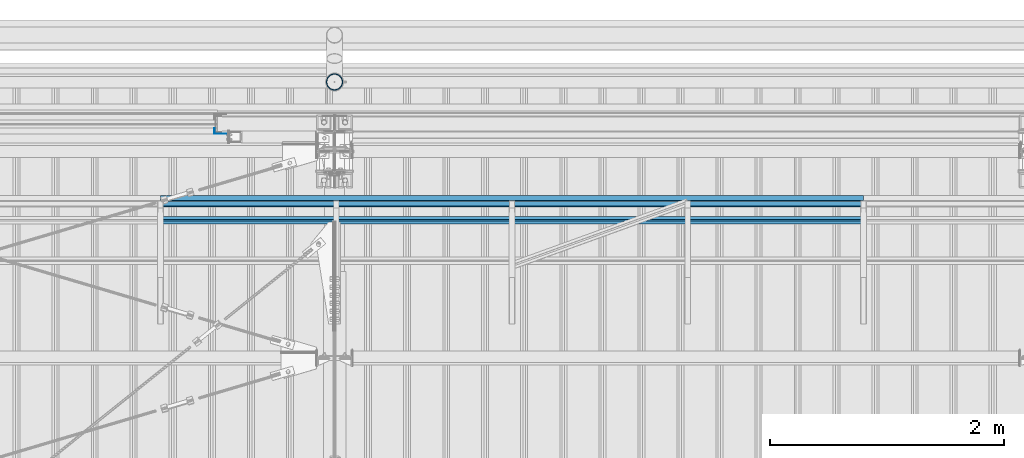
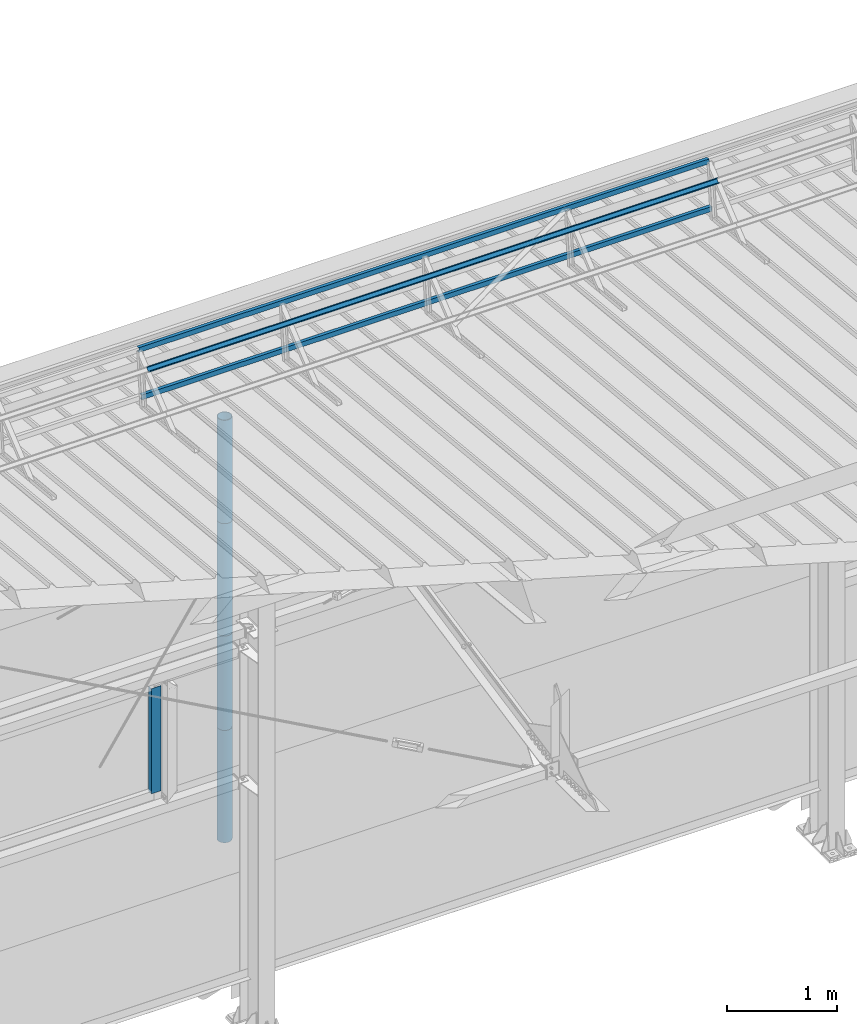
# One storey, part 55 of 709: 8 beams, 8 elements without a shape of their own.
"""IFC4 building model written with IfcOpenShell, lengths in millimetres."""

from ifc_helpers import new_model, si_unit, direction, frame, origin_with_axes, place, context, subcontext, project, spatial, line, indexed_curve, outline, extrude, material, element, aggregate, save


model = new_model("IFC4")

# Units and contexts
model_context = context("Model", 3, precision=0.2, world=origin_with_axes(), true_north=direction((0.0, 1.0)))
body_context = subcontext(model_context, "Body", "Model", "MODEL_VIEW")
ifc_project = project(units=[si_unit("LENGTHUNIT", "METRE", prefix="MILLI"), si_unit("AREAUNIT", "SQUARE_METRE"), si_unit("VOLUMEUNIT", "CUBIC_METRE"), si_unit("MASSUNIT", "GRAM", prefix="KILO"), si_unit("TIMEUNIT", "SECOND"), si_unit("PLANEANGLEUNIT", "RADIAN"), si_unit("SOLIDANGLEUNIT", "STERADIAN"), si_unit("THERMODYNAMICTEMPERATUREUNIT", "DEGREE_CELSIUS"), si_unit("LUMINOUSINTENSITYUNIT", "LUMEN")], contexts=[model_context])

# Site, building, storey
site_placement = place(None, origin_with_axes())
site = spatial("IfcSite", under=ifc_project, at=site_placement, CompositionType="ELEMENT")
building_placement = place(site_placement, origin_with_axes())
building = spatial("IfcBuilding", under=site, at=building_placement, Name="Undefined", CompositionType="ELEMENT")
storey_placement = place(building_placement, origin_with_axes())
storey = spatial("IfcBuildingStorey", under=building, at=storey_placement, Name="Undefined", CompositionType="ELEMENT", Elevation=0.0)

# Assembly, beam
assembly_1_placement = place(storey_placement, frame((14515.0, 21426.91216, 8140.47118), z_axis=(0.0, 0.9950371902, -0.099503719), x_axis=(-1.0, 0.0, 0.0)))
assembly_1 = element("IfcElementAssembly", 1, at=assembly_1_placement, inside=storey)
ifc_material = material(Name="Steel_Undefined", Category="STEEL")
beam_1_placement = place(assembly_1_placement, origin_with_axes())
beam_1 = element("IfcBeam", 2, at=beam_1_placement, material=ifc_material, ObjectType="606", context=body_context, shape_type="SolidModel", body=[
    extrude(outline(indexed_curve([(-20.0, -25.0), (20.0, -25.0), (20.0, -22.5), (-17.5, -22.5), (-17.5, 22.5), (20.0, 22.5), (20.0, 25.0), (-20.0, 25.0)], segments=[line(1, 2, 3, 4, 5, 6, 7, 8, 1)])), frame((0.0, 0.0, 0.0), z_axis=(-1.0, 0.0, 0.0), x_axis=(0.0, 0.0, 1.0)), (0.0, 0.0, -1.0), 6000.0),
])
aggregate(assembly_1, [beam_1])

assembly_2_placement = place(storey_placement, frame((14515.0, 21377.1603, 7642.95259), z_axis=(0.0, 0.9950371902, -0.099503719), x_axis=(-1.0, 0.0, 0.0)))
assembly_2 = element("IfcElementAssembly", 3, at=assembly_2_placement, inside=storey)
beam_2_placement = place(assembly_2_placement, origin_with_axes())
beam_2 = element("IfcBeam", 4, at=beam_2_placement, material=ifc_material, ObjectType="606", context=body_context, shape_type="SolidModel", body=[
    extrude(outline(indexed_curve([(-20.0, -25.0), (20.0, -25.0), (20.0, -22.5), (-17.5, -22.5), (-17.5, 22.5), (20.0, 22.5), (20.0, 25.0), (-20.0, 25.0)], segments=[line(1, 2, 3, 4, 5, 6, 7, 8, 1)])), frame((0.0, 0.0, 0.0), z_axis=(-1.0, 0.0, 0.0), x_axis=(0.0, 0.0, 1.0)), (0.0, 0.0, -1.0), 6000.0),
])
aggregate(assembly_2, [beam_2])

assembly_3_placement = place(storey_placement, frame((14515.0, 21239.5552, 8031.29285), z_axis=(0.0, -0.6332377902, 0.7739572992), x_axis=(-1.0, 0.0, 0.0)))
assembly_3 = element("IfcElementAssembly", 5, at=assembly_3_placement, inside=storey)
beam_3_placement = place(assembly_3_placement, origin_with_axes())
beam_3 = element("IfcBeam", 6, at=beam_3_placement, material=ifc_material, ObjectType="606", context=body_context, shape_type="SolidModel", body=[
    extrude(outline(indexed_curve([(-20.0, -25.0), (20.0, -25.0), (20.0, -22.5), (-17.5, -22.5), (-17.5, 22.5), (20.0, 22.5), (20.0, 25.0), (-20.0, 25.0)], segments=[line(1, 2, 3, 4, 5, 6, 7, 8, 1)])), frame((0.0, 0.0, 0.0), z_axis=(-1.0, 0.0, 0.0), x_axis=(0.0, 0.0, 1.0)), (0.0, 0.0, -1.0), 6000.0),
])
aggregate(assembly_3, [beam_3])

assembly_4_placement = place(storey_placement, frame((8975.0, 22001.0, 3870.0), z_axis=(0.0, -1.0, 0.0), x_axis=(0.0, 0.0, -1.0)))
assembly_4 = element("IfcElementAssembly", 7, at=assembly_4_placement, inside=storey)
beam_4_placement = place(assembly_4_placement, origin_with_axes())
beam_4 = element("IfcBeam", 8, at=beam_4_placement, material=ifc_material, context=body_context, shape_type="SolidModel", body=[
    extrude(outline(indexed_curve([(-25.0, -1.0), (25.0, -1.0), (25.0, 99.0), (23.0, 99.0), (23.0, 1.0), (-25.0, 1.0)], segments=[line(1, 2, 3, 4, 5, 6, 1)])), frame((0.0, 0.0, 0.0), z_axis=(-1.0, 0.0, 0.0), x_axis=(0.0, 0.0, 1.0)), (0.0, 0.0, -1.0), 1170.0),
])
aggregate(assembly_4, [beam_4])

assembly_5_placement = place(storey_placement, frame((10000.0, 22420.0, 6276.92297), z_axis=(0.0, -1.0, 0.0), x_axis=(0.0, 0.0, -1.0)))
assembly_5 = element("IfcElementAssembly", 9, at=assembly_5_placement, inside=storey)
beam_5_placement = place(assembly_5_placement, origin_with_axes())
beam_5 = element("IfcBeam", 10, at=beam_5_placement, material=ifc_material, ObjectType="614", context=body_context, shape_type="SolidModel", body=[
    extrude(outline(indexed_curve([(70.0, 0.0), (69.61653, 7.31699), (68.47033, 14.55382), (66.57396, 21.63119), (63.94818, 28.47157), (60.62178, 35.0), (56.63119, 41.14497), (52.02014, 46.83914), (46.83914, 52.02014), (41.14497, 56.63119), (35.0, 60.62178), (28.47157, 63.94818), (21.63119, 66.57396), (14.55382, 68.47033), (7.31699, 69.61653), (0.0, 70.0), (-7.31699, 69.61653), (-14.55382, 68.47033), (-21.63119, 66.57396), (-28.47157, 63.94818), (-35.0, 60.62178), (-41.14497, 56.63119), (-46.83914, 52.02014), (-52.02014, 46.83914), (-56.63119, 41.14497), (-60.62178, 35.0), (-63.94818, 28.47157), (-66.57396, 21.63119), (-68.47033, 14.55382), (-69.61653, 7.31699), (-70.0, 0.0), (-69.61653, -7.31699), (-68.47033, -14.55382), (-66.57396, -21.63119), (-63.94818, -28.47157), (-60.62178, -35.0), (-56.63119, -41.14497), (-52.02014, -46.83914), (-46.83914, -52.02014), (-41.14497, -56.63119), (-35.0, -60.62178), (-28.47157, -63.94818), (-21.63119, -66.57396), (-14.55382, -68.47033), (-7.31699, -69.61653), (0.0, -70.0), (7.31699, -69.61653), (14.55382, -68.47033), (21.63119, -66.57396), (28.47157, -63.94818), (35.0, -60.62178), (41.14497, -56.63119), (46.83914, -52.02014), (52.02014, -46.83914), (56.63119, -41.14497), (60.62178, -35.0), (63.94818, -28.47157), (66.57396, -21.63119), (68.47033, -14.55382), (69.61653, -7.31699)], segments=[line(1, 2, 3, 4, 5, 6, 7, 8, 9, 10, 11, 12, 13, 14, 15, 16, 17, 18, 19, 20, 21, 22, 23, 24, 25, 26, 27, 28, 29, 30, 31, 32, 33, 34, 35, 36, 37, 38, 39, 40, 41, 42, 43, 44, 45, 46, 47, 48, 49, 50, 51, 52, 53, 54, 55, 56, 57, 58, 59, 60, 1)]), holes=[indexed_curve([(65.0, 0.0), (64.64392, -6.79435), (63.57959, -13.51426), (61.81867, -20.0861), (59.38045, -26.43788), (56.29165, -32.5), (52.5861, -38.20604), (48.30441, -43.49349), (43.49349, -48.30441), (38.20604, -52.5861), (32.5, -56.29165), (26.43788, -59.38045), (20.0861, -61.81867), (13.51426, -63.57959), (6.79435, -64.64392), (0.0, -65.0), (-6.79435, -64.64392), (-13.51426, -63.57959), (-20.0861, -61.81867), (-26.43788, -59.38045), (-32.5, -56.29165), (-38.20604, -52.5861), (-43.49349, -48.30441), (-48.30441, -43.49349), (-52.5861, -38.20604), (-56.29165, -32.5), (-59.38045, -26.43788), (-61.81867, -20.0861), (-63.57959, -13.51426), (-64.64392, -6.79435), (-65.0, 0.0), (-64.64392, 6.79435), (-63.57959, 13.51426), (-61.81867, 20.0861), (-59.38045, 26.43788), (-56.29165, 32.5), (-52.5861, 38.20604), (-48.30441, 43.49349), (-43.49349, 48.30441), (-38.20604, 52.5861), (-32.5, 56.29165), (-26.43788, 59.38045), (-20.0861, 61.81867), (-13.51426, 63.57959), (-6.79435, 64.64392), (0.0, 65.0), (6.79435, 64.64392), (13.51426, 63.57959), (20.0861, 61.81867), (26.43788, 59.38045), (32.5, 56.29165), (38.20604, 52.5861), (43.49349, 48.30441), (48.30441, 43.49349), (52.5861, 38.20604), (56.29165, 32.5), (59.38045, 26.43788), (61.81867, 20.0861), (63.57959, 13.51426), (64.64392, 6.79435)], segments=[line(1, 2, 3, 4, 5, 6, 7, 8, 9, 10, 11, 12, 13, 14, 15, 16, 17, 18, 19, 20, 21, 22, 23, 24, 25, 26, 27, 28, 29, 30, 31, 32, 33, 34, 35, 36, 37, 38, 39, 40, 41, 42, 43, 44, 45, 46, 47, 48, 49, 50, 51, 52, 53, 54, 55, 56, 57, 58, 59, 60, 1)])]), frame((0.0, 0.0, 0.0), z_axis=(-1.0, 0.0, 0.0), x_axis=(0.0, 0.0, 1.0)), (0.0, 0.0, -1.0), 1250.0),
])
aggregate(assembly_5, [beam_5])

assembly_6_placement = place(storey_placement, frame((10000.0, 22420.0, 5126.92297), z_axis=(0.0, -1.0, 0.0), x_axis=(0.0, 0.0, -1.0)))
assembly_6 = element("IfcElementAssembly", 11, at=assembly_6_placement, inside=storey)
beam_6_placement = place(assembly_6_placement, origin_with_axes())
beam_6 = element("IfcBeam", 12, at=beam_6_placement, material=ifc_material, ObjectType="614", context=body_context, shape_type="SolidModel", body=[
    extrude(outline(indexed_curve([(70.0, 0.0), (69.61653, 7.31699), (68.47033, 14.55382), (66.57396, 21.63119), (63.94818, 28.47157), (60.62178, 35.0), (56.63119, 41.14497), (52.02014, 46.83914), (46.83914, 52.02014), (41.14497, 56.63119), (35.0, 60.62178), (28.47157, 63.94818), (21.63119, 66.57396), (14.55382, 68.47033), (7.31699, 69.61653), (0.0, 70.0), (-7.31699, 69.61653), (-14.55382, 68.47033), (-21.63119, 66.57396), (-28.47157, 63.94818), (-35.0, 60.62178), (-41.14497, 56.63119), (-46.83914, 52.02014), (-52.02014, 46.83914), (-56.63119, 41.14497), (-60.62178, 35.0), (-63.94818, 28.47157), (-66.57396, 21.63119), (-68.47033, 14.55382), (-69.61653, 7.31699), (-70.0, 0.0), (-69.61653, -7.31699), (-68.47033, -14.55382), (-66.57396, -21.63119), (-63.94818, -28.47157), (-60.62178, -35.0), (-56.63119, -41.14497), (-52.02014, -46.83914), (-46.83914, -52.02014), (-41.14497, -56.63119), (-35.0, -60.62178), (-28.47157, -63.94818), (-21.63119, -66.57396), (-14.55382, -68.47033), (-7.31699, -69.61653), (0.0, -70.0), (7.31699, -69.61653), (14.55382, -68.47033), (21.63119, -66.57396), (28.47157, -63.94818), (35.0, -60.62178), (41.14497, -56.63119), (46.83914, -52.02014), (52.02014, -46.83914), (56.63119, -41.14497), (60.62178, -35.0), (63.94818, -28.47157), (66.57396, -21.63119), (68.47033, -14.55382), (69.61653, -7.31699)], segments=[line(1, 2, 3, 4, 5, 6, 7, 8, 9, 10, 11, 12, 13, 14, 15, 16, 17, 18, 19, 20, 21, 22, 23, 24, 25, 26, 27, 28, 29, 30, 31, 32, 33, 34, 35, 36, 37, 38, 39, 40, 41, 42, 43, 44, 45, 46, 47, 48, 49, 50, 51, 52, 53, 54, 55, 56, 57, 58, 59, 60, 1)]), holes=[indexed_curve([(65.0, 0.0), (64.64392, -6.79435), (63.57959, -13.51426), (61.81867, -20.0861), (59.38045, -26.43788), (56.29165, -32.5), (52.5861, -38.20604), (48.30441, -43.49349), (43.49349, -48.30441), (38.20604, -52.5861), (32.5, -56.29165), (26.43788, -59.38045), (20.0861, -61.81867), (13.51426, -63.57959), (6.79435, -64.64392), (0.0, -65.0), (-6.79435, -64.64392), (-13.51426, -63.57959), (-20.0861, -61.81867), (-26.43788, -59.38045), (-32.5, -56.29165), (-38.20604, -52.5861), (-43.49349, -48.30441), (-48.30441, -43.49349), (-52.5861, -38.20604), (-56.29165, -32.5), (-59.38045, -26.43788), (-61.81867, -20.0861), (-63.57959, -13.51426), (-64.64392, -6.79435), (-65.0, 0.0), (-64.64392, 6.79435), (-63.57959, 13.51426), (-61.81867, 20.0861), (-59.38045, 26.43788), (-56.29165, 32.5), (-52.5861, 38.20604), (-48.30441, 43.49349), (-43.49349, 48.30441), (-38.20604, 52.5861), (-32.5, 56.29165), (-26.43788, 59.38045), (-20.0861, 61.81867), (-13.51426, 63.57959), (-6.79435, 64.64392), (0.0, 65.0), (6.79435, 64.64392), (13.51426, 63.57959), (20.0861, 61.81867), (26.43788, 59.38045), (32.5, 56.29165), (38.20604, 52.5861), (43.49349, 48.30441), (48.30441, 43.49349), (52.5861, 38.20604), (56.29165, 32.5), (59.38045, 26.43788), (61.81867, 20.0861), (63.57959, 13.51426), (64.64392, 6.79435)], segments=[line(1, 2, 3, 4, 5, 6, 7, 8, 9, 10, 11, 12, 13, 14, 15, 16, 17, 18, 19, 20, 21, 22, 23, 24, 25, 26, 27, 28, 29, 30, 31, 32, 33, 34, 35, 36, 37, 38, 39, 40, 41, 42, 43, 44, 45, 46, 47, 48, 49, 50, 51, 52, 53, 54, 55, 56, 57, 58, 59, 60, 1)])]), frame((0.0, 0.0, 0.0), z_axis=(-1.0, 0.0, 0.0), x_axis=(0.0, 0.0, 1.0)), (0.0, 0.0, -1.0), 1250.0),
])
aggregate(assembly_6, [beam_6])

assembly_7_placement = place(storey_placement, frame((10000.0, 22420.0, 3976.92297), z_axis=(0.0, -1.0, 0.0), x_axis=(0.0, 0.0, -1.0)))
assembly_7 = element("IfcElementAssembly", 13, at=assembly_7_placement, inside=storey)
beam_7_placement = place(assembly_7_placement, origin_with_axes())
beam_7 = element("IfcBeam", 14, at=beam_7_placement, material=ifc_material, ObjectType="614", context=body_context, shape_type="SolidModel", body=[
    extrude(outline(indexed_curve([(70.0, 0.0), (69.61653, 7.31699), (68.47033, 14.55382), (66.57396, 21.63119), (63.94818, 28.47157), (60.62178, 35.0), (56.63119, 41.14497), (52.02014, 46.83914), (46.83914, 52.02014), (41.14497, 56.63119), (35.0, 60.62178), (28.47157, 63.94818), (21.63119, 66.57396), (14.55382, 68.47033), (7.31699, 69.61653), (0.0, 70.0), (-7.31699, 69.61653), (-14.55382, 68.47033), (-21.63119, 66.57396), (-28.47157, 63.94818), (-35.0, 60.62178), (-41.14497, 56.63119), (-46.83914, 52.02014), (-52.02014, 46.83914), (-56.63119, 41.14497), (-60.62178, 35.0), (-63.94818, 28.47157), (-66.57396, 21.63119), (-68.47033, 14.55382), (-69.61653, 7.31699), (-70.0, 0.0), (-69.61653, -7.31699), (-68.47033, -14.55382), (-66.57396, -21.63119), (-63.94818, -28.47157), (-60.62178, -35.0), (-56.63119, -41.14497), (-52.02014, -46.83914), (-46.83914, -52.02014), (-41.14497, -56.63119), (-35.0, -60.62178), (-28.47157, -63.94818), (-21.63119, -66.57396), (-14.55382, -68.47033), (-7.31699, -69.61653), (0.0, -70.0), (7.31699, -69.61653), (14.55382, -68.47033), (21.63119, -66.57396), (28.47157, -63.94818), (35.0, -60.62178), (41.14497, -56.63119), (46.83914, -52.02014), (52.02014, -46.83914), (56.63119, -41.14497), (60.62178, -35.0), (63.94818, -28.47157), (66.57396, -21.63119), (68.47033, -14.55382), (69.61653, -7.31699)], segments=[line(1, 2, 3, 4, 5, 6, 7, 8, 9, 10, 11, 12, 13, 14, 15, 16, 17, 18, 19, 20, 21, 22, 23, 24, 25, 26, 27, 28, 29, 30, 31, 32, 33, 34, 35, 36, 37, 38, 39, 40, 41, 42, 43, 44, 45, 46, 47, 48, 49, 50, 51, 52, 53, 54, 55, 56, 57, 58, 59, 60, 1)]), holes=[indexed_curve([(65.0, 0.0), (64.64392, -6.79435), (63.57959, -13.51426), (61.81867, -20.0861), (59.38045, -26.43788), (56.29165, -32.5), (52.5861, -38.20604), (48.30441, -43.49349), (43.49349, -48.30441), (38.20604, -52.5861), (32.5, -56.29165), (26.43788, -59.38045), (20.0861, -61.81867), (13.51426, -63.57959), (6.79435, -64.64392), (0.0, -65.0), (-6.79435, -64.64392), (-13.51426, -63.57959), (-20.0861, -61.81867), (-26.43788, -59.38045), (-32.5, -56.29165), (-38.20604, -52.5861), (-43.49349, -48.30441), (-48.30441, -43.49349), (-52.5861, -38.20604), (-56.29165, -32.5), (-59.38045, -26.43788), (-61.81867, -20.0861), (-63.57959, -13.51426), (-64.64392, -6.79435), (-65.0, 0.0), (-64.64392, 6.79435), (-63.57959, 13.51426), (-61.81867, 20.0861), (-59.38045, 26.43788), (-56.29165, 32.5), (-52.5861, 38.20604), (-48.30441, 43.49349), (-43.49349, 48.30441), (-38.20604, 52.5861), (-32.5, 56.29165), (-26.43788, 59.38045), (-20.0861, 61.81867), (-13.51426, 63.57959), (-6.79435, 64.64392), (0.0, 65.0), (6.79435, 64.64392), (13.51426, 63.57959), (20.0861, 61.81867), (26.43788, 59.38045), (32.5, 56.29165), (38.20604, 52.5861), (43.49349, 48.30441), (48.30441, 43.49349), (52.5861, 38.20604), (56.29165, 32.5), (59.38045, 26.43788), (61.81867, 20.0861), (63.57959, 13.51426), (64.64392, 6.79435)], segments=[line(1, 2, 3, 4, 5, 6, 7, 8, 9, 10, 11, 12, 13, 14, 15, 16, 17, 18, 19, 20, 21, 22, 23, 24, 25, 26, 27, 28, 29, 30, 31, 32, 33, 34, 35, 36, 37, 38, 39, 40, 41, 42, 43, 44, 45, 46, 47, 48, 49, 50, 51, 52, 53, 54, 55, 56, 57, 58, 59, 60, 1)])]), frame((0.0, 0.0, 0.0), z_axis=(-1.0, 0.0, 0.0), x_axis=(0.0, 0.0, 1.0)), (0.0, 0.0, -1.0), 1250.0),
])
aggregate(assembly_7, [beam_7])

assembly_8_placement = place(storey_placement, frame((10000.0, 22420.0, 2826.92297), z_axis=(0.0, -1.0, 0.0), x_axis=(0.0, 0.0, -1.0)))
assembly_8 = element("IfcElementAssembly", 15, at=assembly_8_placement, inside=storey)
beam_8_placement = place(assembly_8_placement, origin_with_axes())
beam_8 = element("IfcBeam", 16, at=beam_8_placement, material=ifc_material, ObjectType="614", context=body_context, shape_type="SolidModel", body=[
    extrude(outline(indexed_curve([(70.0, 0.0), (69.61653, 7.31699), (68.47033, 14.55382), (66.57396, 21.63119), (63.94818, 28.47157), (60.62178, 35.0), (56.63119, 41.14497), (52.02014, 46.83914), (46.83914, 52.02014), (41.14497, 56.63119), (35.0, 60.62178), (28.47157, 63.94818), (21.63119, 66.57396), (14.55382, 68.47033), (7.31699, 69.61653), (0.0, 70.0), (-7.31699, 69.61653), (-14.55382, 68.47033), (-21.63119, 66.57396), (-28.47157, 63.94818), (-35.0, 60.62178), (-41.14497, 56.63119), (-46.83914, 52.02014), (-52.02014, 46.83914), (-56.63119, 41.14497), (-60.62178, 35.0), (-63.94818, 28.47157), (-66.57396, 21.63119), (-68.47033, 14.55382), (-69.61653, 7.31699), (-70.0, 0.0), (-69.61653, -7.31699), (-68.47033, -14.55382), (-66.57396, -21.63119), (-63.94818, -28.47157), (-60.62178, -35.0), (-56.63119, -41.14497), (-52.02014, -46.83914), (-46.83914, -52.02014), (-41.14497, -56.63119), (-35.0, -60.62178), (-28.47157, -63.94818), (-21.63119, -66.57396), (-14.55382, -68.47033), (-7.31699, -69.61653), (0.0, -70.0), (7.31699, -69.61653), (14.55382, -68.47033), (21.63119, -66.57396), (28.47157, -63.94818), (35.0, -60.62178), (41.14497, -56.63119), (46.83914, -52.02014), (52.02014, -46.83914), (56.63119, -41.14497), (60.62178, -35.0), (63.94818, -28.47157), (66.57396, -21.63119), (68.47033, -14.55382), (69.61653, -7.31699)], segments=[line(1, 2, 3, 4, 5, 6, 7, 8, 9, 10, 11, 12, 13, 14, 15, 16, 17, 18, 19, 20, 21, 22, 23, 24, 25, 26, 27, 28, 29, 30, 31, 32, 33, 34, 35, 36, 37, 38, 39, 40, 41, 42, 43, 44, 45, 46, 47, 48, 49, 50, 51, 52, 53, 54, 55, 56, 57, 58, 59, 60, 1)]), holes=[indexed_curve([(65.0, 0.0), (64.64392, -6.79435), (63.57959, -13.51426), (61.81867, -20.0861), (59.38045, -26.43788), (56.29165, -32.5), (52.5861, -38.20604), (48.30441, -43.49349), (43.49349, -48.30441), (38.20604, -52.5861), (32.5, -56.29165), (26.43788, -59.38045), (20.0861, -61.81867), (13.51426, -63.57959), (6.79435, -64.64392), (0.0, -65.0), (-6.79435, -64.64392), (-13.51426, -63.57959), (-20.0861, -61.81867), (-26.43788, -59.38045), (-32.5, -56.29165), (-38.20604, -52.5861), (-43.49349, -48.30441), (-48.30441, -43.49349), (-52.5861, -38.20604), (-56.29165, -32.5), (-59.38045, -26.43788), (-61.81867, -20.0861), (-63.57959, -13.51426), (-64.64392, -6.79435), (-65.0, 0.0), (-64.64392, 6.79435), (-63.57959, 13.51426), (-61.81867, 20.0861), (-59.38045, 26.43788), (-56.29165, 32.5), (-52.5861, 38.20604), (-48.30441, 43.49349), (-43.49349, 48.30441), (-38.20604, 52.5861), (-32.5, 56.29165), (-26.43788, 59.38045), (-20.0861, 61.81867), (-13.51426, 63.57959), (-6.79435, 64.64392), (0.0, 65.0), (6.79435, 64.64392), (13.51426, 63.57959), (20.0861, 61.81867), (26.43788, 59.38045), (32.5, 56.29165), (38.20604, 52.5861), (43.49349, 48.30441), (48.30441, 43.49349), (52.5861, 38.20604), (56.29165, 32.5), (59.38045, 26.43788), (61.81867, 20.0861), (63.57959, 13.51426), (64.64392, 6.79435)], segments=[line(1, 2, 3, 4, 5, 6, 7, 8, 9, 10, 11, 12, 13, 14, 15, 16, 17, 18, 19, 20, 21, 22, 23, 24, 25, 26, 27, 28, 29, 30, 31, 32, 33, 34, 35, 36, 37, 38, 39, 40, 41, 42, 43, 44, 45, 46, 47, 48, 49, 50, 51, 52, 53, 54, 55, 56, 57, 58, 59, 60, 1)])]), frame((0.0, 0.0, 0.0), z_axis=(-1.0, 0.0, 0.0), x_axis=(0.0, 0.0, 1.0)), (0.0, 0.0, -1.0), 1250.0),
])
aggregate(assembly_8, [beam_8])

save(model, "model.ifc")
